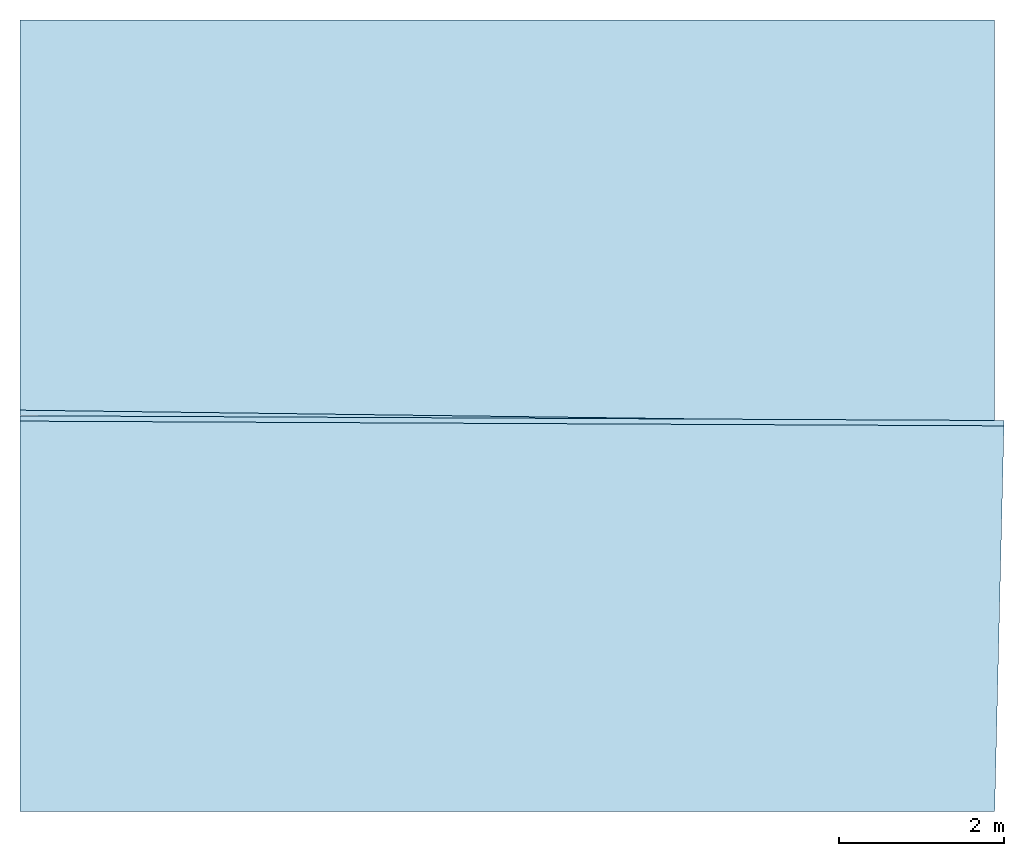
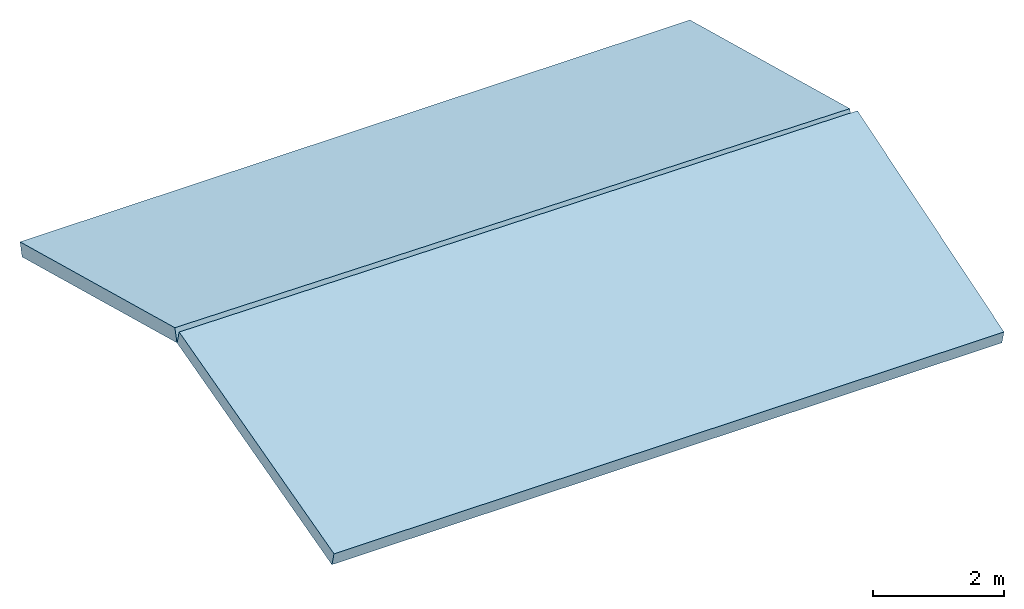
# Not in any storey: 2 slabs.
"""IFC4 model written with IfcOpenShell, lengths in metres."""

import ifcopenshell
import ifcopenshell.guid

model = None  # the IFC model being written
_history = None  # IfcOwnerHistory: only IFC2X3 demands one
_inside = {}  # id of a spatial element -> (the spatial element, [elements in it])
_under = {}  # id of a project, library or spatial element -> (it, [spatial elements below it])
_declared = {}  # id of a project -> (the project, [libraries it declares])
_typed = {}  # id of a type object -> (the type object, [elements of that type])
_made_of = {}  # id of a material, layer set ... -> (it, [elements and type objects made of it])


def new_model(schema):
    """Start an empty IFC model of exactly this schema.

    Asked for "IFC4X3", IfcOpenShell would pick the latest addendum, in which some entities
    have other attributes; the version numbers below select the first issue.
    IFC2X3 requires an IfcOwnerHistory on every rooted entity: one is made here for all.
    """
    global model, _history
    if schema == "IFC4X3":
        model = ifcopenshell.file(schema_version=(4, 3, 0, 0))
    else:
        model = ifcopenshell.file(schema=schema)
    _inside.clear()
    _under.clear()
    _declared.clear()
    _typed.clear()
    _made_of.clear()
    _history = None
    if model.schema == "IFC2X3":
        org = make("IfcOrganization", Name="unknown")
        user = make(
            "IfcPersonAndOrganization",
            ThePerson=make("IfcPerson", FamilyName="unknown"),
            TheOrganization=org,
        )
        app = make(
            "IfcApplication",
            ApplicationDeveloper=org,
            Version="unknown",
            ApplicationFullName="unknown",
            ApplicationIdentifier="unknown",
        )
        _history = make(
            "IfcOwnerHistory",
            OwningUser=user,
            OwningApplication=app,
            ChangeAction="ADDED",
            CreationDate=0,
        )
    return model


def make(cls, **values):
    """One entity of the class cls with the attributes given. An attribute that is None is left unset."""
    return model.create_entity(
        cls, **{name: value for name, value in values.items() if value is not None}
    )


def entity(cls, *values):
    """Any entity or typed value of the class cls, its attributes in the order of the schema. None: left unset."""
    e = model.create_entity(cls)
    for i, value in enumerate(values):
        if value is not None:
            e[i] = value
    return e


def rooted(cls, **values):
    """An entity with a GlobalId (a new one), such as an element, a storey or a relation."""
    return make(cls, GlobalId=ifcopenshell.guid.new(), OwnerHistory=_history, **values)


def si_unit(unit_type, name, prefix=None):
    """IfcSIUnit, for example si_unit("LENGTHUNIT", "METRE", prefix="MILLI")."""
    return make("IfcSIUnit", UnitType=unit_type, Prefix=prefix, Name=name)


def converted_unit(unit_type, name, factor, base, dimensions=None, offset=None):
    """IfcConversionBasedUnit, such as the inch: factor (a typed value) times the base unit."""
    return make(
        "IfcConversionBasedUnit"
        if offset is None
        else "IfcConversionBasedUnitWithOffset",
        ConversionOffset=offset,
        Dimensions=None
        if dimensions is None
        else entity("IfcDimensionalExponents", *dimensions),
        UnitType=unit_type,
        Name=name,
        ConversionFactor=make(
            "IfcMeasureWithUnit", ValueComponent=factor, UnitComponent=base
        ),
    )


def assignment(units):
    """IfcUnitAssignment: the units of a project."""
    return None if units is None else make("IfcUnitAssignment", Units=units)


def point(xyz):
    """IfcCartesianPoint."""
    return None if xyz is None else make("IfcCartesianPoint", Coordinates=xyz)


def direction(xyz):
    """IfcDirection."""
    return None if xyz is None else make("IfcDirection", DirectionRatios=xyz)


def frame(location, z_axis=None, x_axis=None):
    """IfcAxis2Placement3D, a coordinate frame: its origin and axes. An axis left out is left unset."""
    return make(
        "IfcAxis2Placement3D",
        Location=point(location),
        Axis=direction(z_axis),
        RefDirection=direction(x_axis),
    )


def frame_2d(location, x_axis=None):
    """IfcAxis2Placement2D, a coordinate frame in the plane: its origin and x axis."""
    return make(
        "IfcAxis2Placement2D", Location=point(location), RefDirection=direction(x_axis)
    )


def origin_with_axes():
    """The frame at (0, 0, 0) with the z axis (0, 0, 1) and the x axis (1, 0, 0) written out."""
    return frame((0.0, 0.0, 0.0), z_axis=(0.0, 0.0, 1.0), x_axis=(1.0, 0.0, 0.0))


def origin_2d_with_axis():
    """The frame at (0, 0) in the plane with the x axis (1, 0) written out."""
    return frame_2d((0.0, 0.0), x_axis=(1.0, 0.0))


def place(relative_to, where):
    """IfcLocalPlacement: puts the frame where relative to a parent placement (None: the world)."""
    return make(
        "IfcLocalPlacement", PlacementRelTo=relative_to, RelativePlacement=where
    )


def context(
    kind, dimensions, precision=None, world=None, true_north=None, identifier=None
):
    """IfcGeometricRepresentationContext, for example the 3D "Model" context."""
    return make(
        "IfcGeometricRepresentationContext",
        ContextIdentifier=identifier,
        ContextType=kind,
        CoordinateSpaceDimension=dimensions,
        Precision=precision,
        WorldCoordinateSystem=world,
        TrueNorth=true_north,
    )


def subcontext(parent, identifier, kind, view, scale=None):
    """IfcGeometricRepresentationSubContext, for example "Body" below "Model"."""
    return make(
        "IfcGeometricRepresentationSubContext",
        ContextIdentifier=identifier,
        ContextType=kind,
        ParentContext=parent,
        TargetScale=scale,
        TargetView=view,
    )


def project(units=None, contexts=None):
    """IfcProject with its units and contexts."""
    return rooted(
        "IfcProject",
        Name="project",
        RepresentationContexts=contexts,
        UnitsInContext=assignment(units),
    )


def point_list(points):
    """IfcCartesianPointList2D or 3D."""
    cls = (
        "IfcCartesianPointList2D" if len(points[0]) == 2 else "IfcCartesianPointList3D"
    )
    return make(cls, CoordList=points)


def line(*indices):
    """IfcLineIndex: a straight run through numbered points of an indexed curve."""
    return model.create_entity("IfcLineIndex", indices)


def indexed_curve(points, segments=None, self_intersect=None):
    """IfcIndexedPolyCurve: lines and arcs through numbered points (the first is 1)."""
    return make(
        "IfcIndexedPolyCurve",
        Points=point_list(points),
        Segments=segments,
        SelfIntersect=self_intersect,
    )


def outline(outer, holes=None, kind="AREA"):
    """IfcArbitraryClosedProfileDef: a profile drawn as a closed curve; with holes, ...WithVoids."""
    if holes is None:
        return make("IfcArbitraryClosedProfileDef", ProfileType=kind, OuterCurve=outer)
    return make(
        "IfcArbitraryProfileDefWithVoids",
        ProfileType=kind,
        OuterCurve=outer,
        InnerCurves=holes,
    )


def extrude(swept, where, along, depth):
    """IfcExtrudedAreaSolid: the profile swept, set in the frame where, extruded along a direction by depth."""
    return make(
        "IfcExtrudedAreaSolid",
        SweptArea=swept,
        Position=where,
        ExtrudedDirection=direction(along),
        Depth=depth,
    )


def shape(context_of_items, identifier, shape_type, items):
    """IfcShapeRepresentation: the items that make up one representation, for example the "Body"."""
    return make(
        "IfcShapeRepresentation",
        ContextOfItems=context_of_items,
        RepresentationIdentifier=identifier,
        RepresentationType=shape_type,
        Items=items,
    )


def material(Name=None, Category=None):
    """IfcMaterial."""
    return make("IfcMaterial", Name=Name, Category=Category)


def layer(
    of_material, thickness, ventilated=None, Name=None, Category=None, Priority=None
):
    """IfcMaterialLayer: one layer of a wall or slab, of a material (None: an air gap)."""
    return make(
        "IfcMaterialLayer",
        Material=of_material,
        LayerThickness=thickness,
        IsVentilated=ventilated,
        Name=Name,
        Category=Category,
        Priority=Priority,
    )


def layer_set(layers, Name=None):
    """IfcMaterialLayerSet."""
    return make("IfcMaterialLayerSet", MaterialLayers=layers, LayerSetName=Name)


def layer_usage(for_layer_set, set_direction, sense, offset, extent=None):
    """IfcMaterialLayerSetUsage: how a layer set lies in its element."""
    return make(
        "IfcMaterialLayerSetUsage",
        ForLayerSet=for_layer_set,
        LayerSetDirection=set_direction,
        DirectionSense=sense,
        OffsetFromReferenceLine=offset,
        ReferenceExtent=extent,
    )


def made_of(thing, what):
    """Note that an element or type object is made of a material, layer set ...; save() writes the relation."""
    if what is not None:
        _made_of.setdefault(what.id(), (what, []))[1].append(thing)
    return thing


def type_object(cls, material=None, **own):
    """A type object (cls), such as IfcWallType, which elements share."""
    return made_of(rooted(cls, **own), material)


def element(
    cls,
    number,
    at=None,
    inside=None,
    cuts=None,
    type_object=None,
    material=None,
    context=None,
    identifier="Body",
    shape_type=None,
    held_by="IfcProductDefinitionShape",
    body=None,
    shapes=None,
    **own,
):
    """One element of the class cls, such as IfcWall. Its Tag is "e" and its number.

    at: its placement. inside: the storey or other place that contains it. cuts: it is an
    opening in that element (IfcRelVoidsElement). A single representation is given by context,
    identifier, shape_type and body (its items); several are given by shapes. held_by: the class
    of the entity that holds the representations. save() writes the other relations.
    """
    e = rooted(cls, Tag="e%d" % number, ObjectPlacement=at, **own)
    if body is not None:
        shapes = [shape(context, identifier, shape_type, body)]
    if shapes is not None:
        e.Representation = make(held_by, Representations=shapes)
    if inside is not None:
        _inside.setdefault(inside.id(), (inside, []))[1].append(e)
    if cuts is not None:
        rooted(
            "IfcRelVoidsElement", RelatingBuildingElement=cuts, RelatedOpeningElement=e
        )
    if type_object is not None:
        _typed.setdefault(type_object.id(), (type_object, []))[1].append(e)
    return made_of(e, material)


def aggregate(whole, parts):
    """IfcRelAggregates: a whole, such as a stair, and the parts it consists of."""
    return rooted("IfcRelAggregates", RelatingObject=whole, RelatedObjects=parts)


def save(model, path):
    """Write the relations noted so far, then the file.

    IfcRelAggregates (storeys below a building ...), IfcRelContainedInSpatialStructure (elements
    in a storey), IfcRelDefinesByType, IfcRelAssociatesMaterial and IfcRelDeclares: one each for
    every whole, place, type object, material and project.
    """
    for whole, parts in _under.values():
        aggregate(whole, parts)
    for where, things in _inside.values():
        rooted(
            "IfcRelContainedInSpatialStructure",
            RelatedElements=things,
            RelatingStructure=where,
        )
    for kind, things in _typed.values():
        rooted("IfcRelDefinesByType", RelatedObjects=things, RelatingType=kind)
    for what, things in _made_of.values():
        rooted("IfcRelAssociatesMaterial", RelatedObjects=things, RelatingMaterial=what)
    for by, libraries in _declared.values():
        rooted("IfcRelDeclares", RelatingContext=by, RelatedDefinitions=libraries)
    model.write(path)


model = new_model("IFC4")

# Units and contexts
model_context = context("Model", 3, precision=1e-05, world=origin_with_axes())
plan_context = context("Plan", 2, precision=1e-05, world=origin_2d_with_axis())
body_context = subcontext(model_context, "Body", "Model", "MODEL_VIEW")
ifc_project = project(units=[si_unit("VOLUMEUNIT", "CUBIC_METRE"), si_unit("LENGTHUNIT", "METRE"), converted_unit("PLANEANGLEUNIT", "degree", entity("IfcReal", 0.0174532925199433), si_unit("PLANEANGLEUNIT", "RADIAN"), dimensions=[0, 0, 0, 0, 0, 0, 0]), si_unit("AREAUNIT", "SQUARE_METRE")], contexts=[model_context, plan_context])

# Slabs
ifc_material = material(Name="Concrete")
ifc_layer = layer(ifc_material, 0.25, Name="Concrete slab")
ifc_layer_set = layer_set([ifc_layer], Name="solid slab 250")
ifc_layer_usage_1 = layer_usage(ifc_layer_set, "AXIS3", "POSITIVE", 0.0)
slab_type = type_object("IfcSlabType", Name="concrete slab", PredefinedType="FLOOR", material=ifc_layer_set)
slab_1_placement = place(None, frame((9.20320129394531, 5.70378255844116, 5.78999996185303), z_axis=(0.0, -0.258819047126493, 0.965925825746747), x_axis=(1.0, 0.0, 0.0)))
element("IfcSlab", 1, at=slab_1_placement, type_object=slab_type, material=ifc_layer_usage_1, Name="Slab", context=body_context, shape_type="SweptSolid", body=[
    extrude(outline(indexed_curve([(0.0, 0.0), (11.8000011444092, 0.0), (11.912504196167, 4.83062076568604), (9.5367431640625e-07, 4.89011192321777)], segments=[line(4, 1), line(1, 2), line(2, 3), line(3, 4)], self_intersect=False)), None, (0.0, 0.0, 1.0), 0.25),
])
ifc_layer_usage_2 = layer_usage(ifc_layer_set, "AXIS3", "POSITIVE", 0.0)
slab_2_placement = place(None, frame((21.0032043457031, 15.1537837982178, 5.78999996185303), z_axis=(-3.90805899582518e-08, 0.258819047126493, 0.965925825746746), x_axis=(-0.999999999999989, -1.50995802528085e-07, 0.0)))
element("IfcSlab", 2, at=slab_2_placement, type_object=slab_type, material=ifc_layer_usage_2, Name="Slab", context=body_context, shape_type="SweptSolid", body=[
    extrude(outline(indexed_curve([(0.0, 0.0), (11.8000011444092, 0.0), (11.8000030517578, 4.89011192321777), (2.49194044954493e-06, 5.04795551300049)], segments=[line(4, 1), line(1, 2), line(2, 3), line(3, 4)], self_intersect=False)), None, (0.0, 0.0, 1.0), 0.25),
])

save(model, "model.ifc")
